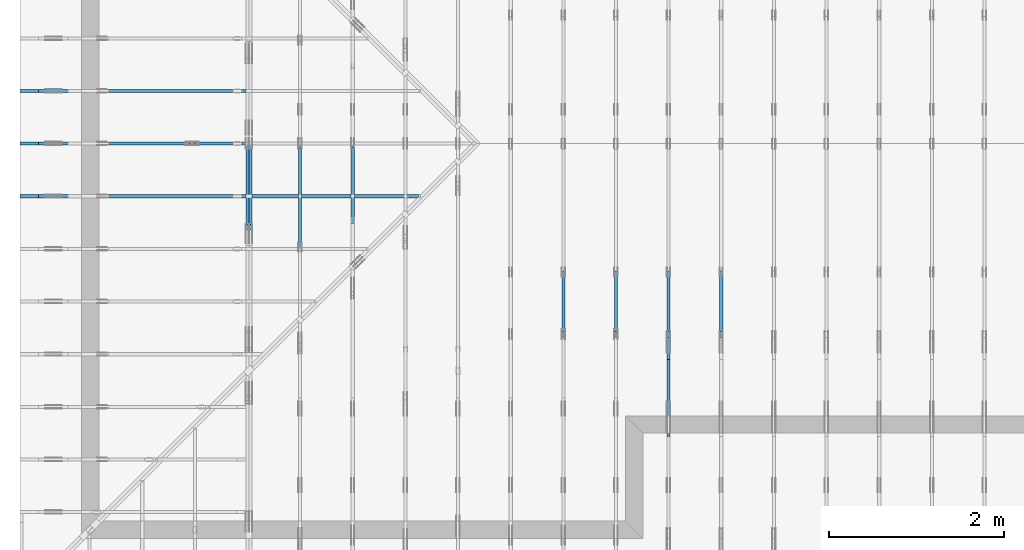
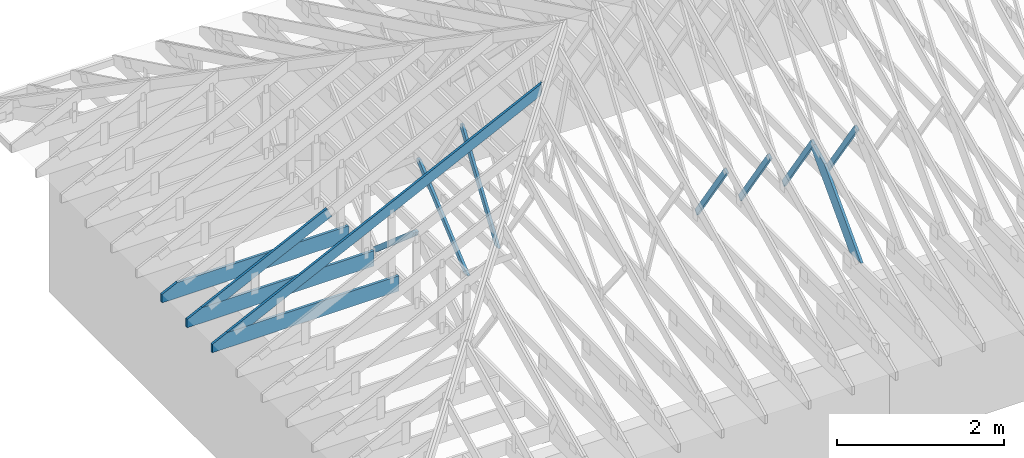
# One storey, part 6 of 159: 14 members, 10 elements without a shape of their own.
"""IFC2X3 building model written with IfcOpenShell, lengths in millimetres."""

from ifc_helpers import new_model, si_unit, frame, origin, origin_with_axes, origin_2d, place, context, project, spatial, faceted_brep, element, aggregate, save


model = new_model("IFC2X3")

# Units and contexts
model_context = context("Model", 3, precision=1e-05, world=origin())
plan_context = context("Plan", 2, precision=1e-05, world=origin_2d())
ifc_project = project(units=[si_unit("LENGTHUNIT", "METRE", prefix="MILLI"), si_unit("AREAUNIT", "SQUARE_METRE"), si_unit("VOLUMEUNIT", "CUBIC_METRE"), si_unit("SOLIDANGLEUNIT", "STERADIAN"), si_unit("PLANEANGLEUNIT", "RADIAN"), si_unit("MASSUNIT", "GRAM"), si_unit("TIMEUNIT", "SECOND"), si_unit("THERMODYNAMICTEMPERATUREUNIT", "DEGREE_CELSIUS"), si_unit("LUMINOUSINTENSITYUNIT", "LUMEN")], contexts=[model_context, plan_context])

# Site, building, storey
site_placement = place(None, origin_with_axes())
site = spatial("IfcSite", under=ifc_project, at=site_placement, CompositionType="ELEMENT")
building_placement = place(site_placement, origin_with_axes())
building = spatial("IfcBuilding", under=site, at=building_placement, Name="Plan 1", CompositionType="ELEMENT")
storey_placement = place(building_placement, origin_with_axes())
storey = spatial("IfcBuildingStorey", under=building, at=storey_placement, Name="Etasje 1", CompositionType="ELEMENT", Elevation=0.0)

# Assembly, member
assembly_1_placement = place(storey_placement, frame((7275.0222614047525, 9699.99999999999, 1.1021457184401395e-15), z_axis=(-1.0, 1.836909530733566e-16, 6.123031769111886e-17), x_axis=(-1.836909530733566e-16, -1.0, 0.0)))
assembly_1 = element("IfcElementAssembly", 1, at=assembly_1_placement, inside=storey, Name="T2 (90)", AssemblyPlace="FACTORY", PredefinedType="TRUSS")
member_1_placement = place(assembly_1_placement, frame((7346.76744651809, 1456.2902443153225, -36.0), z_axis=(0.0, 0.0, 1.0), x_axis=(-0.564247505007227, -0.8256056886269131, 0.0)))
member_1 = element("IfcMember", 2, at=member_1_placement, Name="T2-D42", context=model_context, shape_type="Brep", body=[
    faceted_brep([(1264.6472651905533, 73.00035481239047, 36.0), (8.801394596957834e-05, 73.00035481239047, 36.0), (10.714742691707215, 0.0, 36.0), (1236.1859046261452, 0.0, 36.0), (8.801394596957834e-05, 73.00035481239047, 1.0778243745932505e-20), (1264.6472651905533, 73.00035481239047, 1.5486950762964446e-13), (1236.1859046261452, 0.0, 1.5138411133108407e-13), (10.714742691707215, 0.0, 1.3121341979836537e-15), (10.714685884831852, 0.0001796189581002583, -9.62105002194463e-32), (10.714685884831855, 0.00017961895810048034, 36.0), (-2.6645352591003757e-14, 73.0001796189581, 36.0), (-2.842170943040401e-14, 73.0001796189581, 1.7622623733601546e-30), (1236.1860298817128, 0.00017961895895500981, 5.902699630823587e-29), (1236.1860298817128, 0.0001796189589572141, 36.0), (10.714685884831852, 0.0001796189580938849, 36.0), (10.714685884831852, 0.0001796189580916806, 5.1161877582816205e-31), (1264.6473849238073, 73.00017961895986, 0.0), (1264.6473849238073, 73.00017961895986, 36.0), (1236.1860298817128, 0.00017961895991902566, 36.0), (1236.1860298817128, 0.00017961895991902566, 0.0), (0.0, 73.0001796189581, 0.0), (0.0, 73.0001796189581, 36.0), (1264.6473849238073, 73.00017961895999, 36.0), (1264.6473849238073, 73.00017961895999, 4.733165431326071e-30)], [[[0, 1, 2, 3]], [[4, 5, 6, 7]], [[8, 9, 10, 11]], [[12, 13, 14, 15]], [[16, 17, 18, 19]], [[20, 21, 22, 23]]]),
])
aggregate(assembly_1, [member_1])

# Assembly, members
assembly_2_placement = place(storey_placement, frame((6675.0222614047525, 9699.99999999999, 1.1021457184401395e-15), z_axis=(-1.0, 1.836909530733566e-16, 6.123031769111886e-17), x_axis=(-1.836909530733566e-16, -1.0, 0.0)))
assembly_2 = element("IfcElementAssembly", 3, at=assembly_2_placement, inside=storey, Name="T2 (89)", AssemblyPlace="FACTORY", PredefinedType="TRUSS")
member_2_placement = place(assembly_2_placement, frame((7346.76744651809, 1456.2902443153225, -36.0), z_axis=(0.0, 0.0, 1.0), x_axis=(-0.564247505007227, -0.8256056886269131, 0.0)))
member_2 = element("IfcMember", 4, at=member_2_placement, Name="T2-D42", context=model_context, shape_type="Brep", body=[
    faceted_brep([(1264.6472651905533, 73.00035481239047, 36.0), (8.801394596957834e-05, 73.00035481239047, 36.0), (10.714742691707215, 0.0, 36.0), (1236.1859046261452, 0.0, 36.0), (8.801394596957834e-05, 73.00035481239047, 1.0778243745932505e-20), (1264.6472651905533, 73.00035481239047, 1.5486950762964446e-13), (1236.1859046261452, 0.0, 1.5138411133108407e-13), (10.714742691707215, 0.0, 1.3121341979836537e-15), (10.714685884831852, 0.0001796189581002583, -9.62105002194463e-32), (10.714685884831855, 0.00017961895810048034, 36.0), (-2.6645352591003757e-14, 73.0001796189581, 36.0), (-2.842170943040401e-14, 73.0001796189581, 1.7622623733601546e-30), (1236.1860298817128, 0.00017961895895500981, 5.902699630823587e-29), (1236.1860298817128, 0.0001796189589572141, 36.0), (10.714685884831852, 0.0001796189580938849, 36.0), (10.714685884831852, 0.0001796189580916806, 5.1161877582816205e-31), (1264.6473849238073, 73.00017961895986, 0.0), (1264.6473849238073, 73.00017961895986, 36.0), (1236.1860298817128, 0.00017961895991902566, 36.0), (1236.1860298817128, 0.00017961895991902566, 0.0), (0.0, 73.0001796189581, 0.0), (0.0, 73.0001796189581, 36.0), (1264.6473849238073, 73.00017961895999, 36.0), (1264.6473849238073, 73.00017961895999, 4.733165431326071e-30)], [[[0, 1, 2, 3]], [[4, 5, 6, 7]], [[8, 9, 10, 11]], [[12, 13, 14, 15]], [[16, 17, 18, 19]], [[20, 21, 22, 23]]]),
])
member_3_placement = place(assembly_2_placement, frame((7335.335212521153, 1346.8364569956243, -36.0), z_axis=(0.0, 0.0, 1.0), x_axis=(0.6895311389452021, -0.7242560378933215, 0.0)))
member_3 = element("IfcMember", 5, at=member_3_placement, Name="T2-D3", context=model_context, shape_type="Brep", body=[
    faceted_brep([(1535.8706779051545, 197.99998461177984, 36.0), (266.10350628432207, 197.99998461177984, 36.0), (0.0, 99.00008397742658, 36.0), (21.14596757174968, 0.0, 36.0), (1347.3640424637342, 0.0, 36.0), (266.10350628432207, 197.99998461177984, 3.258720445701937e-14), (1535.8706779051545, 197.99998461177984, 1.880836990812134e-13), (1347.3640424637342, 0.0, 1.6499905673128923e-13), (21.14596757174968, 0.0, 2.5895486246086602e-15), (0.0, 99.00008397742658, 0.0), (0.00014664980380274528, 99.00020530045005, 1.5777218104420236e-30), (0.00014664980380274528, 99.00020530045005, 36.0), (266.10369462794824, 198.00020530010084, 36.0), (266.10369462794824, 198.00020530010084, 3.1554436208840472e-30), (21.146100291866794, 0.00020530010078800842, -2.0402049895968374e-31), (21.146100291866798, 0.0002053001007888966, 36.0), (0.00014664980384182513, 99.00020530045008, 36.0), (0.00014664980383827242, 99.00020530045008, -2.2174136190568693e-30), (1347.3641191793167, 0.00020530010172270798, -1.543300326584409e-30), (1347.3641191793167, 0.00020530010172491227, 36.0), (21.146100291866787, 0.00020530010079060828, 36.0), (21.146100291866787, 0.000205300100788404, -2.4221578316207596e-32), (1535.8708880124423, 198.00020530010443, 1.262177448353619e-29), (1535.8708880124423, 198.00020530010443, 36.0), (1347.364119179317, 0.00020530010181118996, 36.0), (1347.364119179317, 0.00020530010181118996, 1.262177448353619e-29), (266.10369462794824, 198.00020530010084, 1.5777218104420236e-30), (266.10369462794824, 198.00020530010082, 36.0), (1535.8708880124425, 198.0002053001047, 36.0), (1535.8708880124425, 198.0002053001047, 1.735493991486226e-29)], [[[0, 1, 2, 3, 4]], [[5, 6, 7, 8, 9]], [[10, 11, 12, 13]], [[14, 15, 16, 17]], [[18, 19, 20, 21]], [[22, 23, 24, 25]], [[26, 27, 28, 29]]]),
])
aggregate(assembly_2, [member_2, member_3])

# Assembly, member
assembly_3_placement = place(storey_placement, frame((5475.0222614047525, 9699.99999999999, 1.1021457184401395e-15), z_axis=(-1.0, 1.836909530733566e-16, 6.123031769111886e-17), x_axis=(-1.836909530733566e-16, -1.0, 0.0)))
assembly_3 = element("IfcElementAssembly", 6, at=assembly_3_placement, inside=storey, Name="T1 (87)", AssemblyPlace="FACTORY", PredefinedType="TRUSS")
member_4_placement = place(assembly_3_placement, frame((7346.76744651809, 1456.2902443153225, -36.0), z_axis=(0.0, 0.0, 1.0), x_axis=(-0.564247505007227, -0.8256056886269131, 0.0)))
member_4 = element("IfcMember", 7, at=member_4_placement, Name="T1-D42", context=model_context, shape_type="Brep", body=[
    faceted_brep([(1264.6472651905533, 73.00035481239047, 36.0), (8.801394596957834e-05, 73.00035481239047, 36.0), (10.714742691707215, 0.0, 36.0), (1236.1859046261452, 0.0, 36.0), (8.801394596957834e-05, 73.00035481239047, 1.0778243745932505e-20), (1264.6472651905533, 73.00035481239047, 1.5486950762964446e-13), (1236.1859046261452, 0.0, 1.5138411133108407e-13), (10.714742691707215, 0.0, 1.3121341979836537e-15), (10.714685884831852, 0.0001796189581002583, -9.62105002194463e-32), (10.714685884831855, 0.00017961895810048034, 36.0), (-2.6645352591003757e-14, 73.0001796189581, 36.0), (-2.842170943040401e-14, 73.0001796189581, 1.7622623733601546e-30), (1236.1860298817128, 0.00017961895895500981, 5.902699630823587e-29), (1236.1860298817128, 0.0001796189589572141, 36.0), (10.714685884831852, 0.0001796189580938849, 36.0), (10.714685884831852, 0.0001796189580916806, 5.1161877582816205e-31), (1264.6473849238073, 73.00017961895986, 0.0), (1264.6473849238073, 73.00017961895986, 36.0), (1236.1860298817128, 0.00017961895991902566, 36.0), (1236.1860298817128, 0.00017961895991902566, 0.0), (0.0, 73.0001796189581, 0.0), (0.0, 73.0001796189581, 36.0), (1264.6473849238073, 73.00017961895999, 36.0), (1264.6473849238073, 73.00017961895999, 4.733165431326071e-30)], [[[0, 1, 2, 3]], [[4, 5, 6, 7]], [[8, 9, 10, 11]], [[12, 13, 14, 15]], [[16, 17, 18, 19]], [[20, 21, 22, 23]]]),
])
aggregate(assembly_3, [member_4])

# Assembly, members
assembly_4_placement = place(storey_placement, frame((-700.000000000007, 4482.000534935255, 1.1021457184401395e-15), z_axis=(0.0, -1.0, 6.123031769111886e-17), x_axis=(1.0, 0.0, 0.0)))
assembly_4 = element("IfcElementAssembly", 8, at=assembly_4_placement, inside=storey, Name="S1 (23)", AssemblyPlace="FACTORY", PredefinedType="TRUSS")
member_5_placement = place(assembly_4_placement, frame((276.0602239486053, 89.97847693047704, -36.00000195234116), z_axis=(0.0, 0.0, 1.0), x_axis=(0.8987940462991673, 0.43837114678907735, 0.0)))
member_5 = element("IfcMember", 9, at=member_5_placement, Name="S1-O58", context=model_context, shape_type="Brep", body=[
    faceted_brep([(3.1607659707333373e-06, 148.00000315050792, 1.9523411509680955e-06), (3.1607659707333373e-06, 148.00000315050792, 36.00000195234115), (1913.924319567016, 148.0000031505078, 36.00000195234115), (1913.924319567016, 148.0000031505078, 1.9523411509680955e-06), (303.4449717131313, 3.1511761022784412e-06, 1.9523411509680955e-06), (303.4449717131313, 3.1511761022784412e-06, 36.00000195234115), (2.1316282072803006e-14, 148.00000469211633, 36.00000195234115), (2.1316282072803006e-14, 148.00000469211633, 1.9523411509680955e-06), (1913.9243359575016, 3.1509194188109757e-06, 1.9523411509680955e-06), (1913.9243359575016, 3.150919421015267e-06, 36.00000195234115), (303.4449658403142, 3.1509197168457575e-06, 36.00000195234115), (303.4449658403142, 3.150919714641466e-06, 1.9523411509680955e-06), (1913.9243359575016, 148.0000027752494, 1.8783536361866027e-06), (1913.9243359575016, 148.0000027752494, 36.00000195234115), (1913.9243359575016, 0.0, 36.00000255341425), (1913.9243359575016, 0.0, 0.0), (1913.9243359575016, 148.00000315091984, 36.00000195234115), (1.9551251682514703e-05, 148.00000315091984, 36.00000195234115), (303.4449658403143, 3.151176258597843e-06, 36.00000195234115), (1913.9243359575016, 3.151176258597843e-06, 36.00000195234115), (1.955125185304496e-05, 148.00000315050784, 1.952341150968098e-06), (1913.9243359575016, 148.00000315050784, 1.952341385348486e-06), (1913.9243359575016, 3.1509199516221997e-06, 1.952341385348486e-06), (303.4449658403143, 3.1509199516221997e-06, 1.952341188128159e-06)], [[[0, 1, 2, 3]], [[4, 5, 6, 7]], [[8, 9, 10, 11]], [[12, 13, 14, 15]], [[16, 17, 18, 19]], [[20, 21, 22, 23]]]),
])
member_6_placement = place(assembly_4_placement, frame((2575.022261404756, 223.00000000093104, -36.0), z_axis=(0.0, 0.0, 1.0), x_axis=(-1.0, 1.2246063538223773e-16, 0.0)))
member_6 = element("IfcMember", 10, at=member_6_placement, Name="S1-U11", context=model_context, shape_type="Brep", body=[
    faceted_brep([(2575.022261404767, 223.00000000093135, 36.0), (4.4607881136471406e-05, 223.00000000093135, 36.0), (4.4607881136471406e-05, 9.310383575211745e-10, 36.0), (2363.8409717319046, 9.310383575211745e-10, 36.0), (2575.0222614047602, 103.00000000093135, 36.0), (4.4607881136471406e-05, 223.00000000093135, 5.462709467027625e-21), (2575.022261404767, 223.00000000093135, 3.1533886225503443e-13), (2575.0222614047602, 103.00000000093135, 3.1533886225503357e-13), (2363.8409717319046, 9.310383575211745e-10, 2.8947746734085526e-13), (4.4607881136471406e-05, 9.310383575211745e-10, 5.462709467027625e-21), (1.1401554882727804e-25, 9.310383575211745e-10, -6.981208276421509e-42), (2.2042914369942947e-15, 9.310383575211745e-10, 36.0), (2.9513013127233304e-14, 223.00000000093104, 36.0), (2.730872169035303e-14, 223.00000000093104, -1.6721217048386645e-30), (2363.8409657211487, 5.200890442812092e-13, -3.184521740901289e-29), (2363.8409657211487, 5.222933357180895e-13, 36.0), (8.67712118026388e-28, 9.310405618126114e-10, 36.0), (0.0, 9.310383575211745e-10, 0.0), (2575.0222614047602, 103.00000000064097, -5.048709793414476e-29), (2575.0222614047602, 103.00000000064097, 36.0), (2363.840965721148, 4.547473508864641e-13, 36.0), (2363.840965721148, 4.547473508864641e-13, -3.7865323450608567e-29), (2575.0222614047543, 223.00000000093135, -7.825500179792437e-28), (2575.0222614047543, 223.00000000093135, 36.0), (2575.0222614047543, 103.00000000064031, 36.0), (2575.0222614047543, 103.00000000064031, -3.534096855390133e-28), (0.0, 223.00000000093104, 0.0), (0.0, 223.00000000093104, 36.0), (2575.022261404767, 223.00000000093144, 36.0), (2575.022261404767, 223.00000000093146, 6.310887241768095e-30)], [[[0, 1, 2, 3, 4]], [[5, 6, 7, 8, 9]], [[10, 11, 12, 13]], [[14, 15, 16, 17]], [[18, 19, 20, 21]], [[22, 23, 24, 25]], [[26, 27, 28, 29]]]),
])
aggregate(assembly_4, [member_5, member_6])

assembly_5_placement = place(storey_placement, frame((-700.000000000007, 3882.0074014212605, 1.1021457184401395e-15), z_axis=(0.0, -1.0, 6.123031769111886e-17), x_axis=(1.0, 0.0, 0.0)))
assembly_5 = element("IfcElementAssembly", 11, at=assembly_5_placement, inside=storey, Name="S2 (21)", AssemblyPlace="FACTORY", PredefinedType="TRUSS")
member_7_placement = place(assembly_5_placement, frame((276.0601196461637, 89.97842920668349, -36.00000021760033), z_axis=(0.0, 0.0, 1.0), x_axis=(0.8987940462991673, 0.43837114678907735, 0.0)))
member_7 = element("IfcMember", 12, at=member_7_placement, Name="S2-O8", context=model_context, shape_type="Brep", body=[
    faceted_brep([(4846.397758917171, 148.00000083081534, 2.2532740331371315e-06), (4806.344091919849, 147.99999513789555, 35.999997187334884), (4734.159667968751, 3.2119714887812734e-07, 36.000000217601155), (4774.213337911268, -2.2737367544323206e-13, 9.094947017729282e-13), (0.0003410761450481914, 148.00000032047603, 2.1760033064310846e-07), (0.0003410761450481914, 148.00000032047626, 36.00000021760033), (4806.344091076146, 148.00000032047598, 36.00000021760033), (4846.397760051975, 148.00000032047575, 2.1760033064310846e-07), (303.44508638027895, 3.2185664622375043e-07, 2.1760033064310846e-07), (303.44508638027895, 3.2185664622375043e-07, 36.00000021760033), (0.00011466714769170494, 148.00000186279692, 36.00000021760033), (0.00011466714769170494, 148.00000186279692, 2.1760033064310846e-07), (4774.213337825856, 3.211908452808999e-07, 2.1760033064310846e-07), (4734.159668850026, 3.2119085484268794e-07, 36.00000021760033), (303.4452714196058, 3.2119166872483843e-07, 36.00000021760033), (303.4452714196058, 3.21191666520547e-07, 2.1760033064310846e-07), (4806.344093322753, 148.0000003211976, 36.00000021760033), (0.0, 148.0000003211976, 36.00000021760033), (303.4453125, 3.2185684517571644e-07, 36.00000021760033), (4734.15966796875, 3.2185684517571644e-07, 36.00000021760033), (0.00029999575104966425, 148.00000032118817, 2.176003306431452e-07), (4846.397760933251, 148.00000032118817, 2.1760092413605759e-07), (4774.2133355792475, 3.204702352377353e-07, 2.17600915296307e-07), (303.44512421450156, 3.204702352377353e-07, 2.1760036780319118e-07)], [[[0, 1, 2, 3]], [[4, 5, 6, 7]], [[8, 9, 10, 11]], [[12, 13, 14, 15]], [[16, 17, 18, 19]], [[20, 21, 22, 23]]]),
])
member_8_placement = place(assembly_5_placement, frame((2575.0222614047566, 223.00000000093104, -36.0), z_axis=(0.0, 0.0, 1.0), x_axis=(-1.0, 1.2246063538223773e-16, 0.0)))
member_8 = element("IfcMember", 13, at=member_8_placement, Name="S2-U11", context=model_context, shape_type="Brep", body=[
    faceted_brep([(2575.0222614047675, 223.00000000093135, 36.0), (4.4607881591218757e-05, 223.00000000093135, 36.0), (4.4607881591218757e-05, 9.310383575211745e-10, 36.0), (2363.840971731905, 9.310383575211745e-10, 36.0), (2575.0222614047607, 103.00000000093135, 36.0), (4.4607881591218757e-05, 223.00000000093135, 5.4627095227162746e-21), (2575.0222614047675, 223.00000000093135, 3.153388622550345e-13), (2575.0222614047607, 103.00000000093135, 3.153388622550336e-13), (2363.840971731905, 9.310383575211745e-10, 2.894774673408553e-13), (4.4607881591218757e-05, 9.310383575211745e-10, 5.4627095227162746e-21), (1.1401554882727804e-25, 9.310383575211745e-10, -6.981208276421509e-42), (2.2042914369942947e-15, 9.310383575211745e-10, 36.0), (2.9513013127233304e-14, 223.00000000093104, 36.0), (2.730872169035303e-14, 223.00000000093104, -1.6721217048386645e-30), (2363.840965721149, 5.200890442810024e-13, -3.184521740900141e-29), (2363.840965721149, 5.222933357178827e-13, 36.0), (8.67712118026388e-28, 9.310405618126114e-10, 36.0), (0.0, 9.310383575211745e-10, 0.0), (2575.0222614047602, 103.00000000064074, -5.048709793414476e-29), (2575.0222614047602, 103.00000000064074, 36.0), (2363.840965721149, 5.684341886080801e-13, 36.0), (2363.840965721149, 5.684341886080801e-13, -3.7865323450608567e-29), (2575.0222614047548, 223.00000000093135, -7.825500179792437e-28), (2575.0222614047548, 223.00000000093135, 36.0), (2575.0222614047548, 103.00000000064031, 36.0), (2575.0222614047548, 103.00000000064031, -3.534096855390133e-28), (0.0, 223.00000000093104, 0.0), (0.0, 223.00000000093104, 36.0), (2575.0222614047675, 223.00000000093144, 36.0), (2575.0222614047675, 223.00000000093146, 6.310887241768095e-30)], [[[0, 1, 2, 3, 4]], [[5, 6, 7, 8, 9]], [[10, 11, 12, 13]], [[14, 15, 16, 17]], [[18, 19, 20, 21]], [[22, 23, 24, 25]], [[26, 27, 28, 29]]]),
])
aggregate(assembly_5, [member_7, member_8])

# Assembly, member
assembly_6_placement = place(storey_placement, frame((-700.000000000007, 5081.993668449246, 1.1021457184401395e-15), z_axis=(0.0, -1.0, 6.123031769111886e-17), x_axis=(1.0, 0.0, 0.0)))
assembly_6 = element("IfcElementAssembly", 14, at=assembly_6_placement, inside=storey, Name="S2 (15)", AssemblyPlace="FACTORY", PredefinedType="TRUSS")
member_9_placement = place(assembly_6_placement, frame((2575.0222614047566, 223.00000000093104, -36.0), z_axis=(0.0, 0.0, 1.0), x_axis=(-1.0, 1.2246063538223773e-16, 0.0)))
member_9 = element("IfcMember", 15, at=member_9_placement, Name="S2-U11", context=model_context, shape_type="Brep", body=[
    faceted_brep([(2575.0222614047675, 223.00000000093135, 36.0), (4.4607881591218757e-05, 223.00000000093135, 36.0), (4.4607881591218757e-05, 9.310383575211745e-10, 36.0), (2363.840971731905, 9.310383575211745e-10, 36.0), (2575.0222614047607, 103.00000000093135, 36.0), (4.4607881591218757e-05, 223.00000000093135, 5.4627095227162746e-21), (2575.0222614047675, 223.00000000093135, 3.153388622550345e-13), (2575.0222614047607, 103.00000000093135, 3.153388622550336e-13), (2363.840971731905, 9.310383575211745e-10, 2.894774673408553e-13), (4.4607881591218757e-05, 9.310383575211745e-10, 5.4627095227162746e-21), (1.1401554882727804e-25, 9.310383575211745e-10, -6.981208276421509e-42), (2.2042914369942947e-15, 9.310383575211745e-10, 36.0), (2.9513013127233304e-14, 223.00000000093104, 36.0), (2.730872169035303e-14, 223.00000000093104, -1.6721217048386645e-30), (2363.840965721149, 5.200890442810024e-13, -3.184521740900141e-29), (2363.840965721149, 5.222933357178827e-13, 36.0), (8.67712118026388e-28, 9.310405618126114e-10, 36.0), (0.0, 9.310383575211745e-10, 0.0), (2575.0222614047602, 103.00000000064074, -5.048709793414476e-29), (2575.0222614047602, 103.00000000064074, 36.0), (2363.840965721149, 5.684341886080801e-13, 36.0), (2363.840965721149, 5.684341886080801e-13, -3.7865323450608567e-29), (2575.0222614047548, 223.00000000093135, -7.825500179792437e-28), (2575.0222614047548, 223.00000000093135, 36.0), (2575.0222614047548, 103.00000000064031, 36.0), (2575.0222614047548, 103.00000000064031, -3.534096855390133e-28), (0.0, 223.00000000093104, 0.0), (0.0, 223.00000000093104, 36.0), (2575.0222614047675, 223.00000000093144, 36.0), (2575.0222614047675, 223.00000000093146, 6.310887241768095e-30)], [[[0, 1, 2, 3, 4]], [[5, 6, 7, 8, 9]], [[10, 11, 12, 13]], [[14, 15, 16, 17]], [[18, 19, 20, 21]], [[22, 23, 24, 25]], [[26, 27, 28, 29]]]),
])
aggregate(assembly_6, [member_9])

assembly_7_placement = place(storey_placement, frame((3075.02226140475, 9699.999999999993, 1.1021457184401395e-15), z_axis=(-1.0, 1.836909530733566e-16, 6.123031769111886e-17), x_axis=(-1.836909530733566e-16, -1.0, 0.0)))
assembly_7 = element("IfcElementAssembly", 16, at=assembly_7_placement, inside=storey, Name="V3 (4)", AssemblyPlace="FACTORY", PredefinedType="TRUSS")
member_10_placement = place(assembly_7_placement, frame((5169.7670498129255, 1628.085062355916, -36.0), z_axis=(0.0, 0.0, 1.0), x_axis=(0.5603073033813226, -0.8282848095779317, 0.0)))
member_10 = element("IfcMember", 17, at=member_10_placement, Name="V3-D27", context=model_context, shape_type="Brep", body=[
    faceted_brep([(1567.078633488227, 72.9998786910146, 36.0), (24.69105994044321, 72.9998786910146, 36.0), (5.709724928237847e-05, 36.50004148841708, 36.0), (53.956867232901686, 4.241011629346758e-05, 36.0), (1517.6966278018397, 4.241011629346758e-05, 36.0), (24.69105994044321, 72.9998786910146, 3.0236828885675924e-15), (1567.078633488227, 72.9998786910146, 1.9190544515089712e-13), (1517.6966278018397, 4.241011629346758e-05, 1.8585809335809286e-13), (53.956867232901686, 4.241011629346758e-05, 6.607592244576184e-15), (5.709724928237847e-05, 36.50004148841708, 6.992165425698085e-21), (-3.552713678800501e-15, 36.50002378878344, 3.8353687055431256e-31), (0.0, 36.50002378878344, 36.0), (24.69104387395419, 73.00002378878344, 36.0), (24.69104387395419, 73.00002378878344, 2.606900748009894e-31), (53.95681149803045, 2.3788782534950315e-05, -7.888609052210118e-31), (53.95681149803045, 2.3788782538503028e-05, 36.0), (-3.552713678800501e-15, 36.50002378878343, 36.0), (-3.552713678800501e-15, 36.50002378878343, 3.944304526105059e-31), (1517.696643894166, 2.3788783529991024e-05, 5.001557291963444e-29), (1517.696643894166, 2.3788783532195316e-05, 36.0), (53.95681149803045, 2.378878250100895e-05, 36.0), (53.95681149803045, 2.3788782498804657e-05, 1.778142656861743e-30), (1567.0787316420747, 73.00002378878526, 0.0), (1567.0787316420747, 73.00002378878526, 36.0), (1517.6966438941663, 2.378878434683429e-05, 36.0), (1517.6966438941663, 2.378878434683429e-05, 0.0), (24.691043873954186, 73.00002378878344, 0.0), (24.691043873954186, 73.00002378878344, 36.0), (1567.0787316420744, 73.0000237887854, 36.0), (1567.0787316420744, 73.0000237887854, 9.466330862652142e-30)], [[[0, 1, 2, 3, 4]], [[5, 6, 7, 8, 9]], [[10, 11, 12, 13]], [[14, 15, 16, 17]], [[18, 19, 20, 21]], [[22, 23, 24, 25]], [[26, 27, 28, 29]]]),
])
aggregate(assembly_7, [member_10])

assembly_8_placement = place(storey_placement, frame((2475.02226140475, 9699.999999999993, 1.1021457184401395e-15), z_axis=(-1.0, 1.836909530733566e-16, 6.123031769111886e-17), x_axis=(-1.836909530733566e-16, -1.0, 0.0)))
assembly_8 = element("IfcElementAssembly", 18, at=assembly_8_placement, inside=storey, Name="V2 (3)", AssemblyPlace="FACTORY", PredefinedType="TRUSS")
member_11_placement = place(assembly_8_placement, frame((5176.425432139013, 1328.0307208972563, -36.0), z_axis=(0.0, 0.0, 1.0), x_axis=(0.763452554016224, -0.6458639158260079, 0.0)))
member_11 = element("IfcMember", 19, at=member_11_placement, Name="V2-D26", context=model_context, shape_type="Brep", body=[
    faceted_brep([(1568.074621006022, 73.00007556447599, 36.0), (43.145176815131435, 73.00007556447599, 36.0), (4.2464895159355365e-05, 36.50002203584245, 36.0), (30.87820339764494, 5.625391349894926e-05, 36.0), (1481.783979525982, 5.625391349894926e-05, 36.0), (43.145176815131435, 73.00007556447599, 5.283585766459988e-15), (1568.074621006022, 73.00007556447599, 1.9202741441515906e-13), (1481.783979525982, 5.625391349894926e-05, 1.8146020763197249e-13), (30.87820339764494, 5.625391349894926e-05, 3.781364407537571e-15), (4.2464895159355365e-05, 36.50002203584245, 5.200278042654769e-21), (1.0658141036401503e-14, 36.5000000000009, -7.888609052210118e-31), (1.0658141036401503e-14, 36.500000000000895, 36.0), (43.145339968334625, 73.00000000000182, 36.0), (43.145339968334625, 73.00000000000182, -9.860761315262648e-31), (30.878189880510938, 9.041656312547275e-13, 5.9164567891575885e-31), (30.878189880510938, 9.059419880941277e-13, 36.0), (7.105427357601002e-15, 36.500000000000924, 36.0), (7.105427357601002e-15, 36.500000000000924, -5.9164567891575885e-31), (1481.7838517472997, -6.594281499730061e-13, 4.037699511731394e-29), (1481.7838517472997, -6.572238585361258e-13, 36.0), (30.878189880510945, 8.979574832025225e-13, 36.0), (30.878189880510945, 8.957531917656422e-13, 8.41397023301819e-31), (1568.0745316839666, 72.99999999999977, 3.01967414362384e-29), (1568.0745316839666, 72.99999999999977, 36.0), (1481.7838517473, -2.2737367544323206e-13, 36.0), (1481.7838517473, -2.2737367544323206e-13, 1.8271549040638608e-29), (43.14533996833461, 73.00000000000182, 7.888609052210118e-31), (43.14533996833461, 73.00000000000182, 36.0), (1568.0745316839661, 73.00000000000004, 36.0), (1568.0745316839661, 73.00000000000004, 2.3665827156630354e-30)], [[[0, 1, 2, 3, 4]], [[5, 6, 7, 8, 9]], [[10, 11, 12, 13]], [[14, 15, 16, 17]], [[18, 19, 20, 21]], [[22, 23, 24, 25]], [[26, 27, 28, 29]]]),
])
aggregate(assembly_8, [member_11])

# Assembly, members
assembly_9_placement = place(storey_placement, frame((1875.0222614047502, 9699.999999999993, 0.0), z_axis=(-1.0, 1.836909530733566e-16, 6.123031769111886e-17), x_axis=(-1.836909530733566e-16, -1.0, 0.0)))
assembly_9 = element("IfcElementAssembly", 20, at=assembly_9_placement, inside=storey, Name="V1 (2)", AssemblyPlace="FACTORY", PredefinedType="TRUSS")
member_12_placement = place(assembly_9_placement, frame((6152.32811418751, 1090.9200688107462, -36.0), z_axis=(0.0, 0.0, 1.0), x_axis=(-0.7578872008607087, -0.6523856150862922, 0.0)))
member_12 = element("IfcMember", 21, at=member_12_placement, Name="V1-D39", context=model_context, shape_type="Brep", body=[
    faceted_brep([(1245.573770096913, 72.99985882844794, 36.0), (92.31318086220199, 72.99985882844794, 36.0), (2.9179505872889422e-05, 36.49995354797193, 36.0), (42.40248584406709, 0.0001251554831469548, 36.0), (1256.5572136944375, 0.0001251554831469548, 36.0), (1287.9762267614742, 36.49995354797193, 36.0), (92.31318086220199, 72.99985882844794, 1.1304730782540683e-14), (1245.573770096913, 72.99985882844794, 1.5253375530151727e-13), (1287.9762267614742, 36.49995354797193, 1.5772638708642722e-13), (1256.5572136944375, 0.0001251554831469548, 1.5387879478315508e-13), (42.40248584406709, 0.0001251554831469548, 5.192635358250796e-15), (2.9179505872889422e-05, 36.49995354797193, 3.573340829333776e-21), (3.552713678800501e-15, 36.49999999999863, -3.5307423431758246e-31), (3.552713678800501e-15, 36.49999999999862, 36.0), (92.31310374424176, 73.00000000000091, 36.0), (92.31310374424176, 73.00000000000091, 3.472466176443908e-31), (42.40265602386171, 3.552713678800501e-15, -3.944304526105059e-31), (42.40265602386171, 3.552713678800501e-15, 36.0), (-3.552713678800501e-15, 36.49999999999863, 36.0), (-3.552713678800501e-15, 36.49999999999863, 5.9164567891575885e-31), (1256.5572397053338, 1.9218687638600944e-12, 2.1544988848073032e-29), (1256.5572397053338, 1.9240730552969747e-12, 36.0), (42.40265602386171, -9.669530859937911e-15, 36.0), (42.40265602386171, -1.187382229681819e-14, 7.27037911442069e-31), (1287.9762621187194, 36.499999999999886, 1.262177448353619e-29), (1287.9762621187194, 36.499999999999886, 36.0), (1256.5572397053343, 2.2737367544323206e-12, 36.0), (1256.5572397053343, 2.2737367544323206e-12, 1.262177448353619e-29), (1245.5736060948675, 73.00000000000284, 7.097405329399453e-30), (1245.5736060948675, 73.00000000000284, 36.0), (1287.9762621187192, 36.500000000000114, 36.0), (1287.9762621187192, 36.500000000000114, 6.752596044365373e-30), (92.31310374424174, 73.00000000000091, 0.0), (92.31310374424174, 73.00000000000091, 36.0), (1245.5736060948673, 73.00000000000263, 36.0), (1245.5736060948673, 73.00000000000263, -6.310887241768095e-30)], [[[0, 1, 2, 3, 4, 5]], [[6, 7, 8, 9, 10, 11]], [[12, 13, 14, 15]], [[16, 17, 18, 19]], [[20, 21, 22, 23]], [[24, 25, 26, 27]], [[28, 29, 30, 31]], [[32, 33, 34, 35]]]),
])
member_13_placement = place(assembly_9_placement, frame((6152.32811418751, 1090.9200688107462, -72.0), z_axis=(0.0, 0.0, 1.0), x_axis=(-0.7578872008607087, -0.6523856150862922, 0.0)))
member_13 = element("IfcMember", 22, at=member_13_placement, Name="V1-D39", context=model_context, shape_type="Brep", body=[
    faceted_brep([(1245.573770096913, 72.99985882844794, 36.0), (92.31318086220199, 72.99985882844794, 36.0), (2.9179505872889422e-05, 36.49995354797193, 36.0), (42.40248584406709, 0.0001251554831469548, 36.0), (1256.5572136944375, 0.0001251554831469548, 36.0), (1287.9762267614742, 36.49995354797193, 36.0), (92.31318086220199, 72.99985882844794, 1.1304730782540683e-14), (1245.573770096913, 72.99985882844794, 1.5253375530151727e-13), (1287.9762267614742, 36.49995354797193, 1.5772638708642722e-13), (1256.5572136944375, 0.0001251554831469548, 1.5387879478315508e-13), (42.40248584406709, 0.0001251554831469548, 5.192635358250796e-15), (2.9179505872889422e-05, 36.49995354797193, 3.573340829333776e-21), (3.552713678800501e-15, 36.49999999999863, -3.5307423431758246e-31), (3.552713678800501e-15, 36.49999999999862, 36.0), (92.31310374424176, 73.00000000000091, 36.0), (92.31310374424176, 73.00000000000091, 3.472466176443908e-31), (42.40265602386171, 3.552713678800501e-15, -3.944304526105059e-31), (42.40265602386171, 3.552713678800501e-15, 36.0), (-3.552713678800501e-15, 36.49999999999863, 36.0), (-3.552713678800501e-15, 36.49999999999863, 5.9164567891575885e-31), (1256.5572397053338, 1.9218687638600944e-12, 2.1544988848073032e-29), (1256.5572397053338, 1.9240730552969747e-12, 36.0), (42.40265602386171, -9.669530859937911e-15, 36.0), (42.40265602386171, -1.187382229681819e-14, 7.27037911442069e-31), (1287.9762621187194, 36.499999999999886, 1.262177448353619e-29), (1287.9762621187194, 36.499999999999886, 36.0), (1256.5572397053343, 2.2737367544323206e-12, 36.0), (1256.5572397053343, 2.2737367544323206e-12, 1.262177448353619e-29), (1245.5736060948675, 73.00000000000284, 7.097405329399453e-30), (1245.5736060948675, 73.00000000000284, 36.0), (1287.9762621187192, 36.500000000000114, 36.0), (1287.9762621187192, 36.500000000000114, 6.752596044365373e-30), (92.31310374424174, 73.00000000000091, 0.0), (92.31310374424174, 73.00000000000091, 36.0), (1245.5736060948673, 73.00000000000263, 36.0), (1245.5736060948673, 73.00000000000263, -6.310887241768095e-30)], [[[0, 1, 2, 3, 4, 5]], [[6, 7, 8, 9, 10, 11]], [[12, 13, 14, 15]], [[16, 17, 18, 19]], [[20, 21, 22, 23]], [[24, 25, 26, 27]], [[28, 29, 30, 31]], [[32, 33, 34, 35]]]),
])
aggregate(assembly_9, [member_12, member_13])

# Assembly, member
assembly_10_placement = place(storey_placement, frame((6075.0222614047525, 9699.99999999999, 1.1021457184401395e-15), z_axis=(-1.0, 1.836909530733566e-16, 6.123031769111886e-17), x_axis=(-1.836909530733566e-16, -1.0, 0.0)))
assembly_10 = element("IfcElementAssembly", 23, at=assembly_10_placement, inside=storey, Name="T1 (88)", AssemblyPlace="FACTORY", PredefinedType="TRUSS")
member_14_placement = place(assembly_10_placement, frame((7346.76744651809, 1456.2902443153225, -36.0), z_axis=(0.0, 0.0, 1.0), x_axis=(-0.564247505007227, -0.8256056886269131, 0.0)))
member_14 = element("IfcMember", 24, at=member_14_placement, Name="T1-D42", context=model_context, shape_type="Brep", body=[
    faceted_brep([(1264.6472651905533, 73.00035481239047, 36.0), (8.801394596957834e-05, 73.00035481239047, 36.0), (10.714742691707215, 0.0, 36.0), (1236.1859046261452, 0.0, 36.0), (8.801394596957834e-05, 73.00035481239047, 1.0778243745932505e-20), (1264.6472651905533, 73.00035481239047, 1.5486950762964446e-13), (1236.1859046261452, 0.0, 1.5138411133108407e-13), (10.714742691707215, 0.0, 1.3121341979836537e-15), (10.714685884831852, 0.0001796189581002583, -9.62105002194463e-32), (10.714685884831855, 0.00017961895810048034, 36.0), (-2.6645352591003757e-14, 73.0001796189581, 36.0), (-2.842170943040401e-14, 73.0001796189581, 1.7622623733601546e-30), (1236.1860298817128, 0.00017961895895500981, 5.902699630823587e-29), (1236.1860298817128, 0.0001796189589572141, 36.0), (10.714685884831852, 0.0001796189580938849, 36.0), (10.714685884831852, 0.0001796189580916806, 5.1161877582816205e-31), (1264.6473849238073, 73.00017961895986, 0.0), (1264.6473849238073, 73.00017961895986, 36.0), (1236.1860298817128, 0.00017961895991902566, 36.0), (1236.1860298817128, 0.00017961895991902566, 0.0), (0.0, 73.0001796189581, 0.0), (0.0, 73.0001796189581, 36.0), (1264.6473849238073, 73.00017961895999, 36.0), (1264.6473849238073, 73.00017961895999, 4.733165431326071e-30)], [[[0, 1, 2, 3]], [[4, 5, 6, 7]], [[8, 9, 10, 11]], [[12, 13, 14, 15]], [[16, 17, 18, 19]], [[20, 21, 22, 23]]]),
])
aggregate(assembly_10, [member_14])

save(model, "model.ifc")
